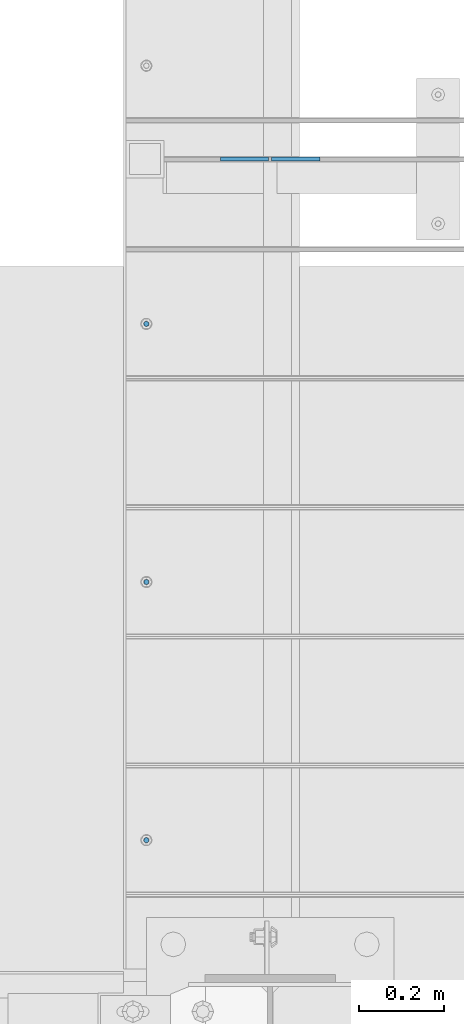
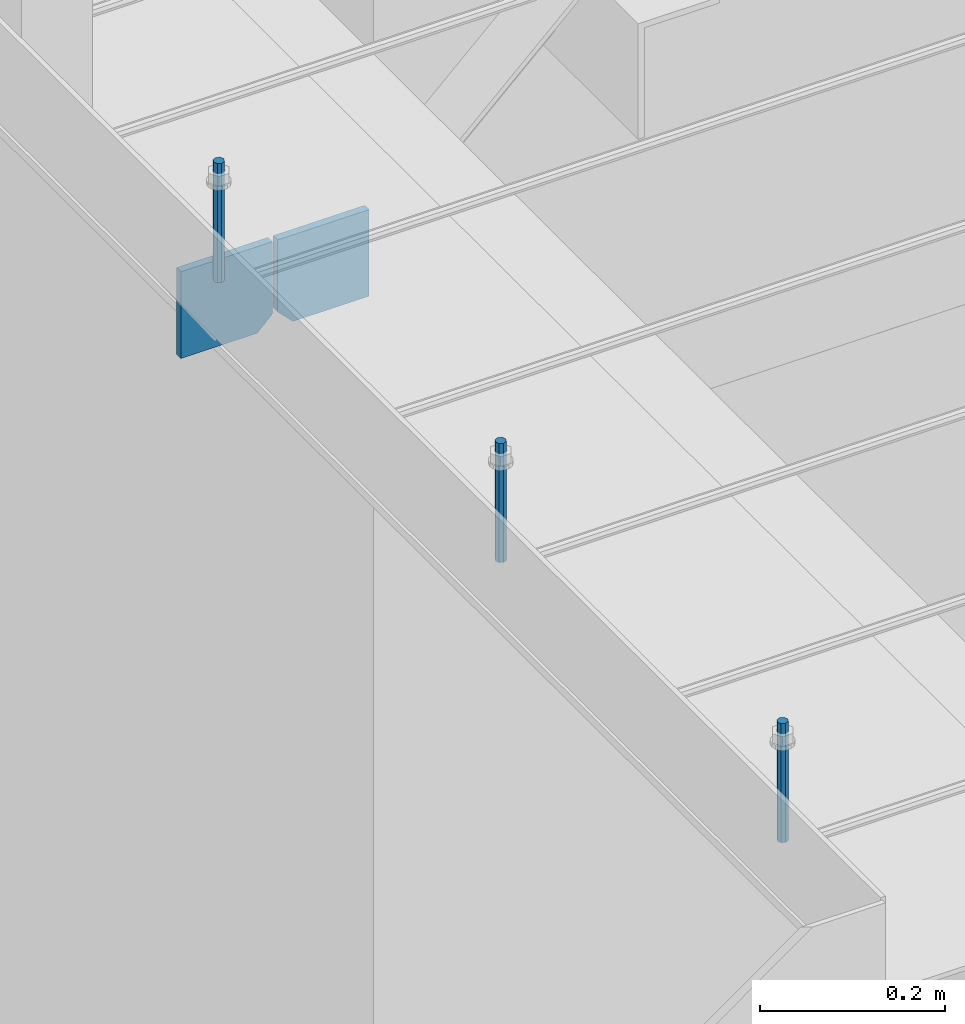
# One storey, part 395 of 1179: 5 columns, 1 element without a shape of its own.
"""IFC2X3 building model written with IfcOpenShell, lengths in millimetres."""

import ifcopenshell
import ifcopenshell.guid

model = None  # the IFC model being written
_history = None  # IfcOwnerHistory: only IFC2X3 demands one
_inside = {}  # id of a spatial element -> (the spatial element, [elements in it])
_under = {}  # id of a project, library or spatial element -> (it, [spatial elements below it])
_declared = {}  # id of a project -> (the project, [libraries it declares])
_typed = {}  # id of a type object -> (the type object, [elements of that type])
_made_of = {}  # id of a material, layer set ... -> (it, [elements and type objects made of it])


def new_model(schema):
    """Start an empty IFC model of exactly this schema.

    Asked for "IFC4X3", IfcOpenShell would pick the latest addendum, in which some entities
    have other attributes; the version numbers below select the first issue.
    IFC2X3 requires an IfcOwnerHistory on every rooted entity: one is made here for all.
    """
    global model, _history
    if schema == "IFC4X3":
        model = ifcopenshell.file(schema_version=(4, 3, 0, 0))
    else:
        model = ifcopenshell.file(schema=schema)
    _inside.clear()
    _under.clear()
    _declared.clear()
    _typed.clear()
    _made_of.clear()
    _history = None
    if model.schema == "IFC2X3":
        org = make("IfcOrganization", Name="unknown")
        user = make(
            "IfcPersonAndOrganization",
            ThePerson=make("IfcPerson", FamilyName="unknown"),
            TheOrganization=org,
        )
        app = make(
            "IfcApplication",
            ApplicationDeveloper=org,
            Version="unknown",
            ApplicationFullName="unknown",
            ApplicationIdentifier="unknown",
        )
        _history = make(
            "IfcOwnerHistory",
            OwningUser=user,
            OwningApplication=app,
            ChangeAction="ADDED",
            CreationDate=0,
        )
    return model


def make(cls, **values):
    """One entity of the class cls with the attributes given. An attribute that is None is left unset."""
    return model.create_entity(
        cls, **{name: value for name, value in values.items() if value is not None}
    )


def rooted(cls, **values):
    """An entity with a GlobalId (a new one), such as an element, a storey or a relation."""
    return make(cls, GlobalId=ifcopenshell.guid.new(), OwnerHistory=_history, **values)


def si_unit(unit_type, name, prefix=None):
    """IfcSIUnit, for example si_unit("LENGTHUNIT", "METRE", prefix="MILLI")."""
    return make("IfcSIUnit", UnitType=unit_type, Prefix=prefix, Name=name)


def assignment(units):
    """IfcUnitAssignment: the units of a project."""
    return None if units is None else make("IfcUnitAssignment", Units=units)


def point(xyz):
    """IfcCartesianPoint."""
    return None if xyz is None else make("IfcCartesianPoint", Coordinates=xyz)


def direction(xyz):
    """IfcDirection."""
    return None if xyz is None else make("IfcDirection", DirectionRatios=xyz)


def frame(location, z_axis=None, x_axis=None):
    """IfcAxis2Placement3D, a coordinate frame: its origin and axes. An axis left out is left unset."""
    return make(
        "IfcAxis2Placement3D",
        Location=point(location),
        Axis=direction(z_axis),
        RefDirection=direction(x_axis),
    )


def origin_with_axes():
    """The frame at (0, 0, 0) with the z axis (0, 0, 1) and the x axis (1, 0, 0) written out."""
    return frame((0.0, 0.0, 0.0), z_axis=(0.0, 0.0, 1.0), x_axis=(1.0, 0.0, 0.0))


def place(relative_to, where):
    """IfcLocalPlacement: puts the frame where relative to a parent placement (None: the world)."""
    return make(
        "IfcLocalPlacement", PlacementRelTo=relative_to, RelativePlacement=where
    )


def context(
    kind, dimensions, precision=None, world=None, true_north=None, identifier=None
):
    """IfcGeometricRepresentationContext, for example the 3D "Model" context."""
    return make(
        "IfcGeometricRepresentationContext",
        ContextIdentifier=identifier,
        ContextType=kind,
        CoordinateSpaceDimension=dimensions,
        Precision=precision,
        WorldCoordinateSystem=world,
        TrueNorth=true_north,
    )


def subcontext(parent, identifier, kind, view, scale=None):
    """IfcGeometricRepresentationSubContext, for example "Body" below "Model"."""
    return make(
        "IfcGeometricRepresentationSubContext",
        ContextIdentifier=identifier,
        ContextType=kind,
        ParentContext=parent,
        TargetScale=scale,
        TargetView=view,
    )


def project(units=None, contexts=None):
    """IfcProject with its units and contexts."""
    return rooted(
        "IfcProject",
        Name="project",
        RepresentationContexts=contexts,
        UnitsInContext=assignment(units),
    )


def spatial(cls, under=None, at=None, **own):
    """A site, building, storey or space (cls), placed at a placement, below another one or the project."""
    s = rooted(cls, ObjectPlacement=at, **own)
    if under is not None:
        _under.setdefault(under.id(), (under, []))[1].append(s)
    return s


def faces_of(points, faces, orient=None, outer=None):
    """IfcFace entities. A face is a list of loops; a loop is a list of indices into points, from 0.

    orient and outer hold one flag for each loop. By default every Orientation is true, the
    first loop of a face is its IfcFaceOuterBound and the others are IfcFaceBound.
    """
    made = []
    for i, loops in enumerate(faces):
        bounds = []
        for j, loop in enumerate(loops):
            is_outer = j == 0 if outer is None else outer[i][j]
            bounds.append(
                make(
                    "IfcFaceOuterBound" if is_outer else "IfcFaceBound",
                    Bound=make("IfcPolyLoop", Polygon=[points[k] for k in loop]),
                    Orientation=True if orient is None else orient[i][j],
                )
            )
        made.append(make("IfcFace", Bounds=bounds))
    return made


def faceted_brep(points, faces, orient=None, outer=None, voids=None):
    """IfcFacetedBrep: a solid bounded by flat faces; with voids (closed shells), ...WithVoids."""
    shared = [point(p) for p in points]
    hull = make("IfcClosedShell", CfsFaces=faces_of(shared, faces, orient, outer))
    if voids is None:
        return make("IfcFacetedBrep", Outer=hull)
    return make(
        "IfcFacetedBrepWithVoids",
        Outer=hull,
        Voids=[
            make(cls, CfsFaces=faces_of(shared, fs, o, b)) for cls, fs, o, b in voids
        ],
    )


def shape(context_of_items, identifier, shape_type, items):
    """IfcShapeRepresentation: the items that make up one representation, for example the "Body"."""
    return make(
        "IfcShapeRepresentation",
        ContextOfItems=context_of_items,
        RepresentationIdentifier=identifier,
        RepresentationType=shape_type,
        Items=items,
    )


def material(Name=None, Category=None):
    """IfcMaterial."""
    return make("IfcMaterial", Name=Name, Category=Category)


def made_of(thing, what):
    """Note that an element or type object is made of a material, layer set ...; save() writes the relation."""
    if what is not None:
        _made_of.setdefault(what.id(), (what, []))[1].append(thing)
    return thing


def type_object(cls, material=None, **own):
    """A type object (cls), such as IfcWallType, which elements share."""
    return made_of(rooted(cls, **own), material)


def element(
    cls,
    number,
    at=None,
    inside=None,
    cuts=None,
    type_object=None,
    material=None,
    context=None,
    identifier="Body",
    shape_type=None,
    held_by="IfcProductDefinitionShape",
    body=None,
    shapes=None,
    **own,
):
    """One element of the class cls, such as IfcWall. Its Tag is "e" and its number.

    at: its placement. inside: the storey or other place that contains it. cuts: it is an
    opening in that element (IfcRelVoidsElement). A single representation is given by context,
    identifier, shape_type and body (its items); several are given by shapes. held_by: the class
    of the entity that holds the representations. save() writes the other relations.
    """
    e = rooted(cls, Tag="e%d" % number, ObjectPlacement=at, **own)
    if body is not None:
        shapes = [shape(context, identifier, shape_type, body)]
    if shapes is not None:
        e.Representation = make(held_by, Representations=shapes)
    if inside is not None:
        _inside.setdefault(inside.id(), (inside, []))[1].append(e)
    if cuts is not None:
        rooted(
            "IfcRelVoidsElement", RelatingBuildingElement=cuts, RelatedOpeningElement=e
        )
    if type_object is not None:
        _typed.setdefault(type_object.id(), (type_object, []))[1].append(e)
    return made_of(e, material)


def aggregate(whole, parts):
    """IfcRelAggregates: a whole, such as a stair, and the parts it consists of."""
    return rooted("IfcRelAggregates", RelatingObject=whole, RelatedObjects=parts)


def save(model, path):
    """Write the relations noted so far, then the file.

    IfcRelAggregates (storeys below a building ...), IfcRelContainedInSpatialStructure (elements
    in a storey), IfcRelDefinesByType, IfcRelAssociatesMaterial and IfcRelDeclares: one each for
    every whole, place, type object, material and project.
    """
    for whole, parts in _under.values():
        aggregate(whole, parts)
    for where, things in _inside.values():
        rooted(
            "IfcRelContainedInSpatialStructure",
            RelatedElements=things,
            RelatingStructure=where,
        )
    for kind, things in _typed.values():
        rooted("IfcRelDefinesByType", RelatedObjects=things, RelatingType=kind)
    for what, things in _made_of.values():
        rooted("IfcRelAssociatesMaterial", RelatedObjects=things, RelatingMaterial=what)
    for by, libraries in _declared.values():
        rooted("IfcRelDeclares", RelatingContext=by, RelatedDefinitions=libraries)
    model.write(path)


model = new_model("IFC2X3")

# Units and contexts
model_context = context("Model", 3, precision=1e-05, world=origin_with_axes())
body_context = subcontext(model_context, "Body", "Model", "MODEL_VIEW")
ifc_project = project(units=[si_unit("LENGTHUNIT", "METRE", prefix="MILLI"), si_unit("AREAUNIT", "SQUARE_METRE"), si_unit("VOLUMEUNIT", "CUBIC_METRE"), si_unit("MASSUNIT", "GRAM", prefix="KILO"), si_unit("TIMEUNIT", "SECOND"), si_unit("PLANEANGLEUNIT", "RADIAN"), si_unit("SOLIDANGLEUNIT", "STERADIAN"), si_unit("THERMODYNAMICTEMPERATUREUNIT", "DEGREE_CELSIUS"), si_unit("LUMINOUSINTENSITYUNIT", "LUMEN")], contexts=[model_context])

# Site, building, storey
site_placement = place(None, origin_with_axes())
site = spatial("IfcSite", under=ifc_project, at=site_placement, CompositionType="ELEMENT")
building_placement = place(site_placement, origin_with_axes())
building = spatial("IfcBuilding", under=site, at=building_placement, Name="Undefined", CompositionType="ELEMENT")
storey_placement = place(building_placement, origin_with_axes())
storey = spatial("IfcBuildingStorey", under=building, at=storey_placement, Name="Undefined", CompositionType="ELEMENT", Elevation=0.0)

# Assembly, columns
assembly_placement = place(storey_placement, origin_with_axes())
assembly = element("IfcElementAssembly", 1, at=assembly_placement, inside=storey, Name="BEAM", AssemblyPlace="NOTDEFINED", PredefinedType="RIGID_FRAME")
ifc_material_1 = material(Name="STEEL/A36")
column_type_1 = type_object("IfcColumnType", PredefinedType="NOTDEFINED")
column_1_placement = place(assembly_placement, frame((16398.875, 7518.40000000001, 3709.9875), z_axis=(1.0, 0.0, 0.0), x_axis=(0.0, 0.0, 1.0)))
column_1 = element("IfcColumn", 2, at=column_1_placement, type_object=column_type_1, material=ifc_material_1, Name="PLATE", context=body_context, shape_type="Brep", body=[
    faceted_brep([(19.0500000000002, 4.76250000000073, 57.1500000000015), (0.0, 4.76250000000073, 38.0999999999985), (0.0, -4.76250000000073, 38.0999999999985), (19.0500000000002, -4.76250000000073, 57.1500000000015), (114.300000000001, 4.76250000000073, 57.1500000000015), (114.300000000001, 4.76250000000073, -57.1500000000015), (0.0, 4.76250000000073, -57.1500000000015), (114.300000000001, -4.76250000000073, 57.1500000000015), (0.0, -4.76250000000073, -57.1500000000015), (114.300000000001, -4.76250000000073, -57.1500000000015)], [[[0, 1, 2, 3]], [[4, 5, 6, 1, 0]], [[7, 4, 0, 3]], [[8, 9, 7, 3, 2]], [[8, 6, 5, 9]], [[7, 9, 5, 4]], [[6, 8, 2, 1]]]),
])
column_2_placement = place(assembly_placement, frame((16519.525, 7518.40000000001, 3709.9875), z_axis=(-1.0, 0.0, 0.0), x_axis=(0.0, 0.0, 1.0)))
column_2 = element("IfcColumn", 3, at=column_2_placement, type_object=column_type_1, material=ifc_material_1, Name="PLATE", context=body_context, shape_type="Brep", body=[
    faceted_brep([(19.0500000000002, 4.76250000000073, 57.1500000000015), (0.0, 4.76250000000073, 38.0999999999985), (0.0, -4.76250000000073, 38.0999999999985), (19.0500000000002, -4.76250000000073, 57.1500000000015), (114.300000000001, 4.76250000000073, 57.1500000000015), (114.300000000001, 4.76250000000073, -57.1500000000015), (0.0, 4.76250000000073, -57.1500000000015), (114.300000000001, -4.76250000000073, 57.1500000000015), (0.0, -4.76250000000073, -57.1500000000015), (114.300000000001, -4.76250000000073, -57.1500000000015)], [[[0, 1, 2, 3]], [[4, 5, 6, 1, 0]], [[7, 4, 0, 3]], [[8, 9, 7, 3, 2]], [[8, 6, 5, 9]], [[7, 9, 5, 4]], [[6, 8, 2, 1]]]),
])
ifc_material_2 = material(Name="STEEL/A307")
column_type_2 = type_object("IfcColumnType", PredefinedType="NOTDEFINED")
column_3_placement = place(assembly_placement, frame((16167.1, 7129.4625, 4108.45), z_axis=(0.0, 1.0, 0.0), x_axis=(0.0, 0.0, 1.0)))
column_3 = element("IfcColumn", 4, at=column_3_placement, type_object=column_type_2, material=ifc_material_2, Name="THREADED ROD", context=body_context, shape_type="Brep", body=[
    faceted_brep([(0.0, -6.34999999999854, 0.0), (0.0, -4.49012806053361, -4.49012806053452), (157.162499999999, -4.49012806053361, -4.49012806053361), (157.162499999999, -6.34999999999854, 0.0), (0.0, 0.0, -6.34999999999991), (157.162499999999, 0.0, -6.34999999999854), (0.0, 4.49012806053361, -4.49012806053452), (157.162499999999, 4.49012806053361, -4.49012806053361), (0.0, 6.34999999999854, 0.0), (157.162499999999, 6.34999999999854, 0.0), (0.0, 4.49012806053361, 4.49012806053452), (157.162499999999, 4.49012806053361, 4.49012806053361), (0.0, 0.0, 6.34999999999991), (157.162499999999, 0.0, 6.34999999999854), (0.0, -4.49012806053361, 4.49012806053452), (157.162499999999, -4.49012806053361, 4.49012806053361)], [[[0, 1, 2, 3]], [[1, 4, 5, 2]], [[4, 6, 7, 5]], [[6, 8, 9, 7]], [[8, 10, 11, 9]], [[10, 12, 13, 11]], [[12, 14, 15, 13]], [[14, 0, 3, 15]], [[5, 7, 9, 11, 13, 15, 3, 2]], [[14, 12, 10, 8, 6, 4, 1, 0]]]),
])
column_4_placement = place(assembly_placement, frame((16167.1, 5910.2625, 4108.45), z_axis=(0.0, 1.0, 0.0), x_axis=(0.0, 0.0, 1.0)))
column_4 = element("IfcColumn", 5, at=column_4_placement, type_object=column_type_2, material=ifc_material_2, Name="THREADED ROD", context=body_context, shape_type="Brep", body=[
    faceted_brep([(0.0, -6.34999999999854, 0.0), (0.0, -4.49012806053361, -4.49012806053452), (157.162499999999, -4.49012806053361, -4.49012806053361), (157.162499999999, -6.34999999999854, 0.0), (0.0, 0.0, -6.34999999999991), (157.162499999999, 0.0, -6.34999999999854), (0.0, 4.49012806053361, -4.49012806053452), (157.162499999999, 4.49012806053361, -4.49012806053361), (0.0, 6.34999999999854, 0.0), (157.162499999999, 6.34999999999854, 0.0), (0.0, 4.49012806053361, 4.49012806053452), (157.162499999999, 4.49012806053361, 4.49012806053361), (0.0, 0.0, 6.34999999999991), (157.162499999999, 0.0, 6.34999999999854), (0.0, -4.49012806053361, 4.49012806053452), (157.162499999999, -4.49012806053361, 4.49012806053361)], [[[0, 1, 2, 3]], [[1, 4, 5, 2]], [[4, 6, 7, 5]], [[6, 8, 9, 7]], [[8, 10, 11, 9]], [[10, 12, 13, 11]], [[12, 14, 15, 13]], [[14, 0, 3, 15]], [[5, 7, 9, 11, 13, 15, 3, 2]], [[14, 12, 10, 8, 6, 4, 1, 0]]]),
])
column_5_placement = place(assembly_placement, frame((16167.1, 6519.8625, 4108.45), z_axis=(0.0, 1.0, 0.0), x_axis=(0.0, 0.0, 1.0)))
column_5 = element("IfcColumn", 6, at=column_5_placement, type_object=column_type_2, material=ifc_material_2, Name="THREADED ROD", context=body_context, shape_type="Brep", body=[
    faceted_brep([(0.0, -6.34999999999854, 0.0), (0.0, -4.49012806053361, -4.49012806053452), (157.162499999999, -4.49012806053361, -4.49012806053361), (157.162499999999, -6.34999999999854, 0.0), (0.0, 0.0, -6.34999999999991), (157.162499999999, 0.0, -6.34999999999854), (0.0, 4.49012806053361, -4.49012806053452), (157.162499999999, 4.49012806053361, -4.49012806053361), (0.0, 6.34999999999854, 0.0), (157.162499999999, 6.34999999999854, 0.0), (0.0, 4.49012806053361, 4.49012806053452), (157.162499999999, 4.49012806053361, 4.49012806053361), (0.0, 0.0, 6.34999999999991), (157.162499999999, 0.0, 6.34999999999854), (0.0, -4.49012806053361, 4.49012806053452), (157.162499999999, -4.49012806053361, 4.49012806053361)], [[[0, 1, 2, 3]], [[1, 4, 5, 2]], [[4, 6, 7, 5]], [[6, 8, 9, 7]], [[8, 10, 11, 9]], [[10, 12, 13, 11]], [[12, 14, 15, 13]], [[14, 0, 3, 15]], [[5, 7, 9, 11, 13, 15, 3, 2]], [[14, 12, 10, 8, 6, 4, 1, 0]]]),
])
aggregate(assembly, [column_3, column_4, column_5, column_1, column_2])

save(model, "model.ifc")
